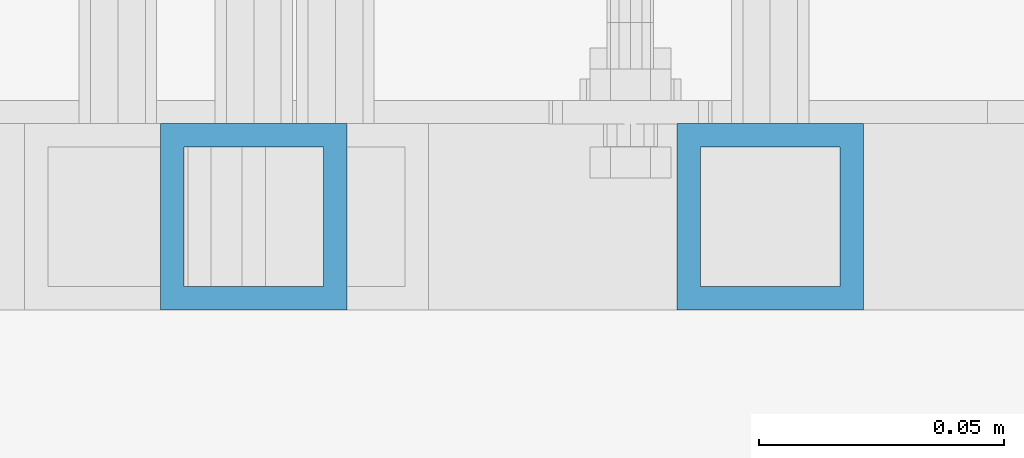
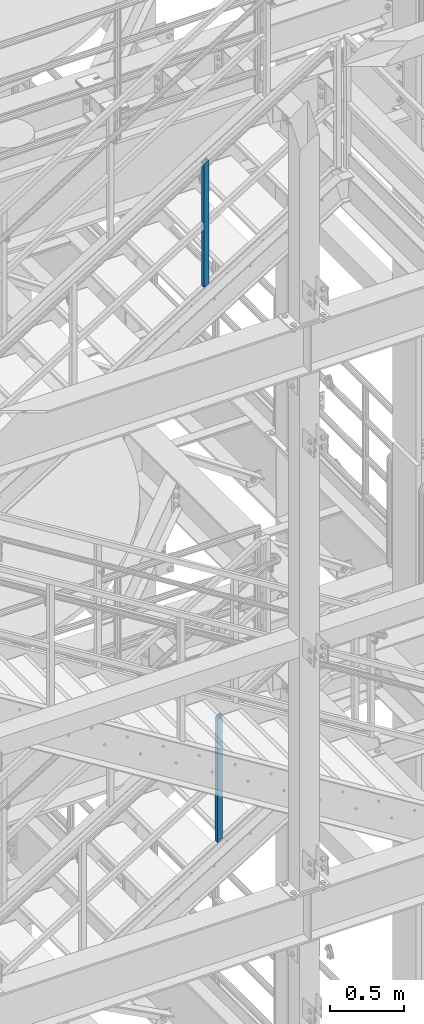
# One storey, part 627 of 1876: 2 columns, 2 elements without a shape of their own.
"""IFC2X3 building model written with IfcOpenShell, lengths in millimetres."""

from ifc_helpers import new_model, si_unit, frame, origin_with_axes, place, context, subcontext, project, spatial, faceted_brep, material, type_object, element, aggregate, save


model = new_model("IFC2X3")

# Units and contexts
model_context = context("Model", 3, precision=1e-05, world=origin_with_axes())
body_context = subcontext(model_context, "Body", "Model", "MODEL_VIEW")
ifc_project = project(units=[si_unit("LENGTHUNIT", "METRE", prefix="MILLI"), si_unit("AREAUNIT", "SQUARE_METRE"), si_unit("VOLUMEUNIT", "CUBIC_METRE"), si_unit("MASSUNIT", "GRAM", prefix="KILO"), si_unit("TIMEUNIT", "SECOND"), si_unit("PLANEANGLEUNIT", "RADIAN"), si_unit("SOLIDANGLEUNIT", "STERADIAN"), si_unit("THERMODYNAMICTEMPERATUREUNIT", "DEGREE_CELSIUS"), si_unit("LUMINOUSINTENSITYUNIT", "LUMEN")], contexts=[model_context])

# Site, building, storey
site_placement = place(None, origin_with_axes())
site = spatial("IfcSite", under=ifc_project, at=site_placement, CompositionType="ELEMENT")
building_placement = place(site_placement, origin_with_axes())
building = spatial("IfcBuilding", under=site, at=building_placement, Name="Undefined", CompositionType="ELEMENT")
storey_placement = place(building_placement, origin_with_axes())
storey = spatial("IfcBuildingStorey", under=building, at=storey_placement, Name="Undefined", CompositionType="ELEMENT", Elevation=0.0)

# Assembly, column
assembly_1_placement = place(storey_placement, origin_with_axes())
assembly_1 = element("IfcElementAssembly", 1, at=assembly_1_placement, inside=storey, Name="RAIL", AssemblyPlace="NOTDEFINED", PredefinedType="RIGID_FRAME")
ifc_material = material()
column_type = type_object("IfcColumnType", Name="HSS1-1/2X1-1/2X3/16", PredefinedType="NOTDEFINED")
column_1_placement = place(assembly_1_placement, frame((5213.35000009587, -5734.05000114554, 12805.9825795812), z_axis=(-1.0, 0.0, 0.0), x_axis=(0.0, 0.0, 1.0)))
column_1 = element("IfcColumn", 2, at=column_1_placement, type_object=column_type, material=ifc_material, Name="POST", ObjectType="HSS1-1/2X1-1/2X3/16", context=body_context, shape_type="Brep", body=[
    faceted_brep([(1026.33175871902, -19.0500000000002, -19.0499992350001), (1026.33175871902, 19.0499992349996, -19.0499992350001), (1002.89450115962, 19.0499992349996, 19.0499992349996), (1002.89450115962, -19.0499992349996, 19.0499992349996), (1023.40208377724, -14.2874994260001, -14.2874994260001), (1005.82416013402, -14.2874994260001, 14.2874994260001), (1005.82416013402, 14.2874994260001, 14.2874994260001), (1023.40208377724, 14.2874994260001, -14.2874994260001), (-11.7186358969739, 19.0499992349996, 19.0499992349996), (-11.7186358969739, -19.0499992349996, 19.0499992349996), (11.7186358969793, -19.0499992349996, -19.0499992349996), (11.7186358969793, 19.0499992349996, -19.0499992349996), (-8.78902482466219, 14.2874994260001, 14.2874994260001), (-8.78902482466219, -14.2874994260001, 14.2874994260001), (8.78902482575359, -14.2874994260001, -14.2874994260001), (8.78902482575359, 14.2874994260001, -14.2874994260001)], [[[0, 1, 2, 3], [4, 5, 6, 7]], [[8, 9, 3, 2]], [[9, 10, 0, 3]], [[10, 11, 1, 0]], [[11, 8, 2, 1]], [[10, 9, 8, 11], [12, 13, 14, 15]], [[15, 14, 4, 7]], [[12, 15, 7, 6]], [[13, 12, 6, 5]], [[14, 13, 5, 4]]]),
])
aggregate(assembly_1, [column_1])

assembly_2_placement = place(storey_placement, origin_with_axes())
assembly_2 = element("IfcElementAssembly", 3, at=assembly_2_placement, inside=storey, Name="RAIL", AssemblyPlace="NOTDEFINED", PredefinedType="RIGID_FRAME")
column_2_placement = place(assembly_2_placement, frame((5107.78124790345, -5734.05000114554, 17410.4110946903), z_axis=(-1.0, 0.0, 0.0), x_axis=(0.0, 0.0, 1.0)))
column_2 = element("IfcColumn", 4, at=column_2_placement, type_object=column_type, material=ifc_material, Name="POST", ObjectType="HSS1-1/2X1-1/2X3/16", context=body_context, shape_type="Brep", body=[
    faceted_brep([(1026.31311450052, -19.0500000000002, -19.0499992349996), (1026.31311450052, 19.0499992349996, -19.0499992349996), (1002.71048974224, 19.0499992349996, 19.0499992349996), (1002.71048974224, -19.0499992349996, 19.0499992349996), (1023.36278640575, -14.2874994260001, -14.2874994260001), (1005.66081783739, -14.2874994260001, 14.2874994260001), (1005.66081783739, 14.2874994260001, 14.2874994260001), (1023.36278640575, 14.2874994260001, -14.2874994260001), (-11.8013123776254, 19.0499992349996, 19.0499992349996), (-11.8013123776254, -19.0499992349996, 19.0499992349996), (11.8013123805795, -19.0499992349996, -19.0499992349996), (11.8013123805795, 19.0499992349996, -19.0499992349996), (-8.85098428269339, 14.2874994260001, 14.2874994260001), (-8.85098428269339, -14.2874994260001, 14.2874994260001), (8.85098428565107, -14.2874994260001, -14.2874994260001), (8.85098428565107, 14.2874994260001, -14.2874994260001)], [[[0, 1, 2, 3], [4, 5, 6, 7]], [[8, 9, 3, 2]], [[9, 10, 0, 3]], [[10, 11, 1, 0]], [[11, 8, 2, 1]], [[10, 9, 8, 11], [12, 13, 14, 15]], [[15, 14, 4, 7]], [[12, 15, 7, 6]], [[13, 12, 6, 5]], [[14, 13, 5, 4]]]),
])
aggregate(assembly_2, [column_2])

save(model, "model.ifc")
